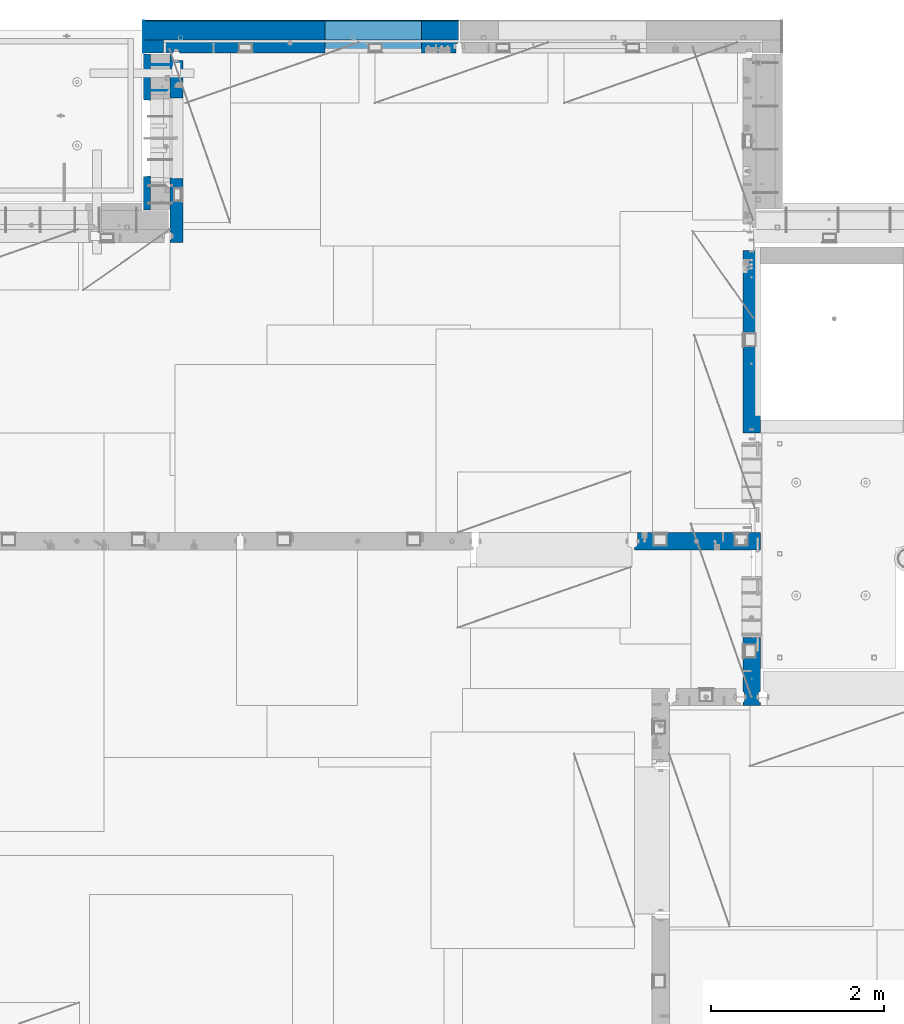
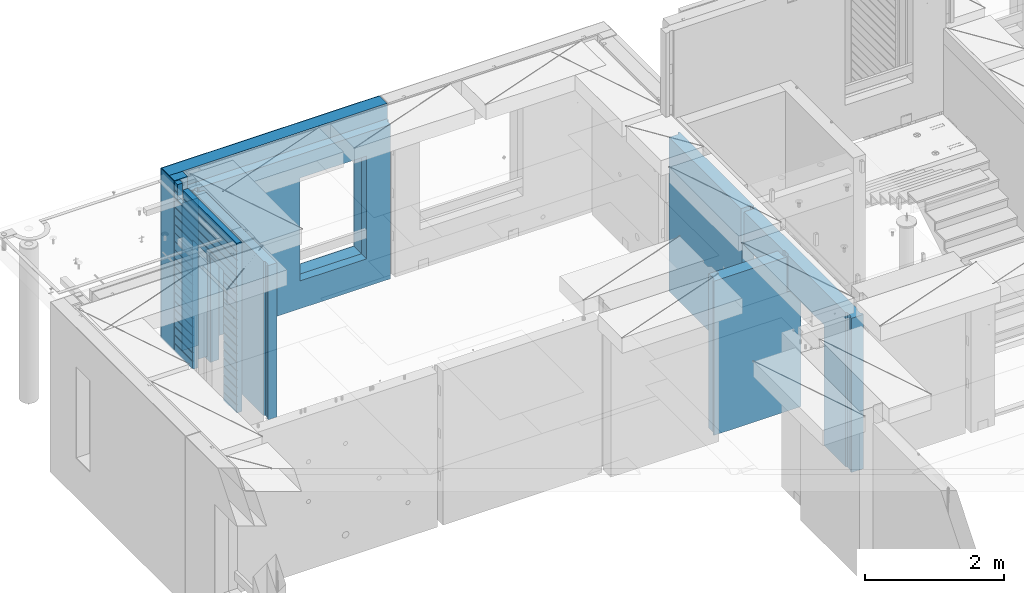
# One storey, part 228 of 341: 12 walls, 5 elements without a shape of their own.
"""IFC2X3 building model written with IfcOpenShell, lengths in millimetres."""

from ifc_helpers import new_model, si_unit, frame, origin_with_axes, place, context, subcontext, project, spatial, faceted_brep, material, type_object, element, aggregate, save


model = new_model("IFC2X3")

# Units and contexts
model_context = context("Model", 3, precision=1e-05, world=origin_with_axes())
body_context = subcontext(model_context, "Body", "Model", "MODEL_VIEW")
ifc_project = project(units=[si_unit("LENGTHUNIT", "METRE", prefix="MILLI"), si_unit("AREAUNIT", "SQUARE_METRE"), si_unit("VOLUMEUNIT", "CUBIC_METRE"), si_unit("MASSUNIT", "GRAM", prefix="KILO"), si_unit("TIMEUNIT", "SECOND"), si_unit("PLANEANGLEUNIT", "RADIAN"), si_unit("SOLIDANGLEUNIT", "STERADIAN"), si_unit("THERMODYNAMICTEMPERATUREUNIT", "DEGREE_CELSIUS"), si_unit("LUMINOUSINTENSITYUNIT", "LUMEN")], contexts=[model_context])

# Site, building, storey
site_placement = place(None, origin_with_axes())
site = spatial("IfcSite", under=ifc_project, at=site_placement, CompositionType="ELEMENT")
building_placement = place(site_placement, origin_with_axes())
building = spatial("IfcBuilding", under=site, at=building_placement, CompositionType="ELEMENT")
storey_placement = place(building_placement, origin_with_axes())
storey = spatial("IfcBuildingStorey", under=building, at=storey_placement, Name="5", CompositionType="ELEMENT", Elevation=0.0)

# Assembly, walls
assembly_1_placement = place(storey_placement, origin_with_axes())
assembly_1 = element("IfcElementAssembly", 1, at=assembly_1_placement, inside=storey, AssemblyPlace="NOTDEFINED", PredefinedType="REINFORCEMENT_UNIT")
ifc_material_1 = material(Name="Undefined")
wall_type_1 = type_object("IfcWallType", PredefinedType="NOTDEFINED")
wall_1_placement = place(assembly_1_placement, frame((11020.0, 22485.0002441406, 95115.0), z_axis=(0.0, 0.0, 1.0), x_axis=(-1.0, 3.00000001838171e-08, 0.0)))
wall_1 = element("IfcWall", 2, at=wall_1_placement, type_object=wall_type_1, material=ifc_material_1, Name="(PD)", context=body_context, shape_type="Brep", body=[
    faceted_brep([(0.0, 5.0, -1300.0), (0.0, 5.0, 1300.0), (280.0, 5.0, 1300.0), (280.0, 5.0, -1300.0), (0.0, -5.0, 1300.0), (280.0, -5.0, 1300.0), (0.0, -5.0, -1300.0), (280.0, -5.0, -1300.0)], [[[0, 1, 2, 3]], [[1, 4, 5, 2]], [[4, 6, 7, 5]], [[6, 0, 3, 7]], [[5, 7, 3, 2]], [[6, 4, 1, 0]]]),
])
wall_2_placement = place(assembly_1_placement, frame((11020.0, 22185.0002441406, 95115.0), z_axis=(0.0, 0.0, 1.0), x_axis=(-1.0, 3.00000001838171e-08, 0.0)))
wall_2 = element("IfcWall", 3, at=wall_2_placement, type_object=wall_type_1, material=ifc_material_1, Name="(PD)", context=body_context, shape_type="Brep", body=[
    faceted_brep([(0.0, 5.0, -1300.0), (0.0, 5.0, 1300.0), (280.0, 5.0, 1300.0), (280.0, 5.0, -1300.0), (0.0, -5.0, 1300.0), (280.0, -5.0, 1300.0), (0.0, -5.0, -1300.0), (280.0, -5.0, -1300.0)], [[[0, 1, 2, 3]], [[1, 4, 5, 2]], [[4, 6, 7, 5]], [[6, 0, 3, 7]], [[5, 7, 3, 2]], [[6, 4, 1, 0]]]),
])

# Assembly, wall
assembly_2_placement = place(storey_placement, origin_with_axes())
assembly_2 = element("IfcElementAssembly", 4, at=assembly_2_placement, inside=storey, AssemblyPlace="NOTDEFINED", PredefinedType="REINFORCEMENT_UNIT")
ifc_material_2 = material(Name="CONCRETE/C25/30")
wall_type_2 = type_object("IfcWallType", PredefinedType="NOTDEFINED")
wall_3_placement = place(assembly_2_placement, frame((17710.0, 18214.9992663657, 95112.5), z_axis=(0.0, 0.0, 1.0), x_axis=(0.0, 1.0, 0.0)))
wall_3 = element("IfcWall", 5, at=wall_3_placement, type_object=wall_type_2, material=ifc_material_2, context=body_context, shape_type="Brep", body=[
    faceted_brep([(2120.00073363433, -57.0000000000036, 1357.5), (2120.00073363433, -57.0000000000036, -1357.5), (2120.00073363433, 100.0, -1357.5), (2120.00073363433, 100.0, 1357.5), (2165.00073363433, -70.0000000000036, 1357.5), (2165.00073363433, -70.0000000000036, -1357.5), (45.0, 100.0, 1357.5), (45.0, 100.0, 762.5), (45.0, -57.0, 762.5), (45.0, -57.0, 1357.5), (15.0, -70.0, 762.5), (15.0, 100.0, 762.5), (15.0, -70.0, 1357.5), (15.0, 100.0, -1357.5), (15.0, -100.0, -1357.5), (15.0, -100.0, 1357.5), (2165.00073363433, -100.0, -1357.5), (2165.00073363433, -100.0, 1357.5)], [[[0, 1, 2, 3]], [[4, 5, 1, 0]], [[6, 7, 8, 9]], [[10, 8, 7, 11]], [[12, 9, 8, 10]], [[11, 13, 14, 15, 12, 10]], [[15, 14, 16, 17]], [[3, 6, 9, 12, 15, 17, 4, 0]], [[13, 11, 7, 6, 3, 2]], [[16, 14, 13, 2, 1, 5]], [[17, 16, 5, 4]]]),
])
aggregate(assembly_2, [wall_3])

assembly_3_placement = place(storey_placement, origin_with_axes())
assembly_3 = element("IfcElementAssembly", 6, at=assembly_3_placement, inside=storey, AssemblyPlace="NOTDEFINED", PredefinedType="REINFORCEMENT_UNIT")
wall_4_placement = place(assembly_3_placement, frame((17710.0, 15080.0, 95112.5), z_axis=(0.0, 0.0, 1.0), x_axis=(0.0, 1.0, 0.0)))
wall_4 = element("IfcWall", 7, at=wall_4_placement, type_object=wall_type_2, material=ifc_material_2, context=body_context, shape_type="Brep", body=[
    faceted_brep([(3089.99926636568, -57.0, 1357.5), (3089.99926636568, -57.0, 762.5), (3089.99926620436, 100.0, 762.5), (3089.99926636568, 100.0, 1357.5), (3119.99926636568, -70.0, 1357.5), (3119.99926636568, -69.9999995451544, 762.5), (1965.00000368528, 100.0, 1357.5), (1965.00000368528, 99.9999997455598, 762.5), (1951.9999991369, 80.0000000823711, 762.5), (1951.9999991369, 80.0000000823711, 1357.5), (1848.00000041054, 79.9999993903439, 762.5), (1848.00000041054, 79.9999993903439, 1357.5), (1835.0, 100.0, 762.5), (1835.0, 100.0, 1357.5), (790.003238525391, -100.0, -1357.5), (790.003238525391, 100.0, -1357.5), (790.003238525391, 100.0, 762.5), (790.003238525391, -100.0, 762.5), (164.999999999998, 100.0, -1357.5), (164.999999999996, 100.0, 1357.5), (47.9997742438973, -79.9991481948964, 1357.5), (47.9997742438991, -79.9991481948928, -1357.5), (152.000000457021, -79.9991466091124, -1357.5), (152.000000457019, -79.9991466091124, 1357.5), (34.9997701872417, -100.0, 1357.5), (34.9997701872435, -100.0, -1357.5), (0.0, -100.0, 1357.5), (0.0, -100.0, -1357.5), (0.0, 100.0, 1357.5), (0.0, 100.0, -1357.5), (35.0, 100.0, 1357.5), (35.0, 100.0, -1357.5), (48.0, 80.0, 1357.5), (48.0, 80.0, -1357.5), (152.0, 80.0, 1357.5), (152.0, 80.0, -1357.5), (165.0, -100.0, -1357.5), (164.999999999998, -99.9991455078125, 1357.5), (3119.99926636568, -100.0, 762.5), (3119.99926636568, -100.0, 1357.5)], [[[0, 1, 2, 3]], [[4, 5, 1, 0]], [[6, 7, 8, 9]], [[9, 8, 10, 11]], [[11, 10, 12, 13]], [[14, 15, 16, 17]], [[13, 12, 16, 15, 18, 19]], [[20, 21, 22, 23]], [[24, 25, 21, 20]], [[26, 27, 25, 24]], [[27, 26, 28, 29]], [[29, 28, 30, 31]], [[32, 33, 31, 30]], [[34, 35, 33, 32]], [[19, 18, 35, 34]], [[15, 14, 36, 22, 21, 25, 27, 29, 31, 33, 35, 18]], [[37, 23, 22, 36]], [[14, 17, 38, 39, 37, 36]], [[13, 19, 34, 32, 30, 28, 26, 24, 20, 23, 37, 39, 4, 0, 3, 6, 9, 11]], [[7, 6, 3, 2]], [[38, 17, 16, 12, 10, 8, 7, 2, 1, 5]], [[39, 38, 5, 4]]]),
])
aggregate(assembly_3, [wall_4])

assembly_4_placement = place(storey_placement, origin_with_axes())
assembly_4 = element("IfcElementAssembly", 8, at=assembly_4_placement, inside=storey, AssemblyPlace="NOTDEFINED", PredefinedType="REINFORCEMENT_UNIT")
wall_5_placement = place(assembly_4_placement, frame((16359.9991042544, 16980.0, 95112.5), z_axis=(0.0, 0.0, 1.0), x_axis=(1.0, 0.0, 0.0)))
wall_5 = element("IfcWall", 9, at=wall_5_placement, type_object=wall_type_2, material=ifc_material_2, context=body_context, shape_type="Brep", body=[
    faceted_brep([(1185.00089736511, 100.0, 1357.5), (1185.00089574558, -57.0, 1357.5), (1185.00089574558, -57.0, 742.5), (1185.00089736511, 99.9999999278843, 742.5), (1220.00089574558, -70.2708332915754, 1357.5), (1220.00089574558, -70.270833291579, 742.5), (1220.00089574558, 100.000001967095, 742.5), (0.0, -100.0, -1357.5), (0.0, -100.0, 1357.5), (0.0, -70.0000178764712, 1357.5), (0.0, -70.0000178764712, -1357.5), (30.0000412533973, -57.0, 1357.5), (30.0000412533973, -57.0, -1357.5), (30.0000000000009, 100.0, 1357.5), (30.0, 100.0, -1357.5), (1450.0, 100.0, -1357.5), (1450.0, -100.0, -1357.5), (1450.00089574558, 100.0, 742.5), (1450.0, -100.0, 742.5), (1220.00089574558, -100.0, 1357.5), (1220.00089574558, -100.0, 742.5), (1225.00089532057, 100.0, 742.5)], [[[0, 1, 2, 3]], [[4, 5, 2, 1]], [[6, 3, 2, 5]], [[7, 8, 9, 10]], [[11, 12, 10, 9]], [[13, 14, 12, 11]], [[15, 16, 7, 10, 12, 14]], [[16, 15, 17, 18]], [[19, 8, 7, 16, 18, 20]], [[17, 21, 6, 5, 20, 18]], [[19, 20, 5, 4]], [[0, 13, 11, 9, 8, 19, 4, 1]], [[21, 17, 15, 14, 13, 0, 3, 6]]]),
])
aggregate(assembly_4, [wall_5])

# Assembly, walls
assembly_5_placement = place(storey_placement, origin_with_axes())
assembly_5 = element("IfcElementAssembly", 10, at=assembly_5_placement, inside=storey, AssemblyPlace="NOTDEFINED", PredefinedType="REINFORCEMENT_UNIT")
ifc_material_3 = material()
wall_type_3 = type_object("IfcWallType", PredefinedType="NOTDEFINED")
wall_6_placement = place(assembly_5_placement, frame((10805.0, 22620.0, 95247.5), z_axis=(0.0, 0.0, 1.0), x_axis=(0.0, 1.0, 0.0)))
wall_6 = element("IfcWall", 11, at=wall_6_placement, type_object=wall_type_3, material=ifc_material_3, context=body_context, shape_type="Brep", body=[
    faceted_brep([(0.0, 110.0, -1492.5), (0.0, 110.0, 1492.5), (150.0, 110.0, 1492.5), (150.0, 110.0, -1492.5), (0.0, -110.0, 1492.5), (150.0, -110.0, 1492.5), (0.0, -110.0, -1492.5), (150.0, -110.0, -1492.5)], [[[0, 1, 2, 3]], [[1, 4, 5, 2]], [[4, 6, 7, 5]], [[6, 0, 3, 7]], [[5, 7, 3, 2]], [[6, 4, 1, 0]]]),
])
wall_7_placement = place(assembly_5_placement, frame((10915.0, 22880.0, 95247.5), z_axis=(0.0, 0.0, 1.0), x_axis=(1.0, 0.0, 0.0)))
wall_7 = element("IfcWall", 12, at=wall_7_placement, type_object=wall_type_3, material=ifc_material_3, context=body_context, shape_type="Brep", body=[
    faceted_brep([(-220.0, -110.0, -1492.5), (-220.0, 110.0, -1492.5), (3410.0, 110.0, -1492.5), (3410.0, -110.0, -1492.5), (-220.0, -110.0, 1492.5), (-220.0, 110.0, 1492.5), (3410.0, -110.0, 1492.5), (3410.0, 110.0, 1492.5), (1869.99971073172, 110.0, -1002.5), (2979.99971073172, 110.0, -1002.5), (2979.99971073172, 110.0, 807.5), (1869.99971073172, 110.0, 807.5), (1869.99971073172, -110.0, -1002.5), (1869.99971073172, -110.0, 807.5), (2979.99971073172, -110.0, 807.5), (2979.99971073172, -110.0, -1002.5)], [[[0, 1, 2, 3]], [[0, 4, 5, 1]], [[5, 4, 6, 7]], [[1, 5, 7, 2], [8, 9, 10, 11]], [[6, 3, 2, 7]], [[4, 0, 3, 6], [12, 13, 14, 15]], [[10, 14, 13, 11]], [[9, 15, 14, 10]], [[8, 12, 15, 9]], [[11, 13, 12, 8]]]),
])

# Wall
ifc_material_4 = material(Name="CONCRETE/C30/37")
wall_type_4 = type_object("IfcWallType", PredefinedType="NOTDEFINED")
wall_8_placement = place(assembly_1_placement, frame((10727.5, 20805.0, 95247.5), z_axis=(0.0, 0.0, 1.0), x_axis=(0.0, 1.0, 0.0)))
wall_8 = element("IfcWall", 13, at=wall_8_placement, type_object=wall_type_4, material=ifc_material_4, context=body_context, shape_type="Brep", body=[
    faceted_brep([(1800.0, -42.5, 1492.5), (1800.0, 42.5, 1492.5), (1705.0, 42.5, 1492.5), (1705.0, -42.5, 1492.5), (0.0, 42.5, -1492.5), (0.0, 42.5, -1357.00000005524), (384.998212827581, 42.5, -1357.00000005524), (384.998212827581, 42.5, -1492.5), (0.0, 32.4999992507037, -1355.00000000074), (386.174879582417, 32.4999992506928, -1355.0000000008), (0.0, 32.4999991127006, -1344.99999959956), (386.174879598653, 32.4999991126915, -1344.99999959957), (0.0, 42.5, -1343.00000011075), (384.998212827581, 42.5, -1343.00000011075), (0.0, 42.5, -1207.00000005524), (384.998212827581, 42.5, -1207.00000005524), (0.0, 32.4999992507037, -1205.00000000074), (386.174879582417, 32.4999992506928, -1205.0000000008), (0.0, 32.4999991127006, -1194.99999959956), (386.174879598653, 32.4999991126915, -1194.99999959957), (0.0, 42.5, -1193.00000011075), (384.998212827581, 42.5, -1193.00000011075), (0.0, 42.5, -1057.00000005524), (384.998212827581, 42.5, -1057.00000005524), (0.0, 32.4999992507037, -1055.00000000074), (386.174879582417, 32.4999992506928, -1055.0000000008), (0.0, 32.4999991127006, -1044.99999959956), (386.174879598653, 32.4999991126915, -1044.99999959957), (0.0, 42.5, -1043.00000011075), (384.998212827581, 42.5, -1043.00000011075), (0.0, 42.5, -907.000000055239), (384.998212827581, 42.5, -907.000000055239), (0.0, 32.4999992507037, -905.000000000742), (386.174879582417, 32.4999992506928, -905.0000000008), (0.0, 32.4999991127006, -894.99999959956), (386.174879598653, 32.4999991126915, -894.999999599575), (0.0, 42.5, -893.000000110755), (384.998212827581, 42.5, -893.000000110755), (0.0, 42.5, -757.000000055239), (384.998212827581, 42.5, -757.000000055239), (0.0, 32.4999992507037, -755.000000000742), (386.174879582417, 32.4999992506928, -755.0000000008), (0.0, 32.4999991127006, -744.99999959956), (386.174879598653, 32.4999991126915, -744.999999599575), (0.0, 42.5, -743.000000110755), (384.998212827581, 42.5, -743.000000110755), (0.0, 42.5, -607.000000055239), (384.998212827581, 42.5, -607.000000055239), (3.63797880709171e-12, 32.4999992507037, -605.000000000742), (386.174879582417, 32.4999992506928, -605.0000000008), (3.63797880709171e-12, 32.4999991127006, -594.99999959956), (386.174879598653, 32.4999991126915, -594.999999599575), (0.0, 42.5, -593.000000110755), (384.998212827581, 42.5, -593.000000110755), (0.0, 42.5, -457.000000055239), (384.998212827581, 42.5, -457.000000055239), (0.0, 32.4999992507037, -455.000000000742), (386.174879582417, 32.4999992506928, -455.0000000008), (0.0, 32.4999991127006, -444.99999959956), (386.174879598653, 32.4999991126915, -444.999999599575), (0.0, 42.5, -443.000000110755), (384.998212827581, 42.5, -443.000000110755), (0.0, 42.5, -307.000000055239), (384.998212827581, 42.5, -307.000000055239), (0.0, 32.4999992507037, -305.000000000742), (386.174879582417, 32.4999992506928, -305.0000000008), (0.0, 32.4999991127006, -294.99999959956), (386.174879598653, 32.4999991126915, -294.999999599575), (0.0, 42.5, -293.000000110755), (384.998212827581, 42.5, -293.000000110755), (0.0, 42.5, -157.000000055239), (384.998212827581, 42.5, -157.000000055239), (3.63797880709171e-12, 32.4999992507037, -155.000000000742), (386.174879582417, 32.4999992506928, -155.0000000008), (3.63797880709171e-12, 32.4999991127006, -144.99999959956), (386.174879598653, 32.4999991126915, -144.999999599575), (0.0, 42.5, -143.000000110755), (384.998212827581, 42.5, -143.000000110755), (0.0, 42.5, -7.00000005523907), (384.998212827581, 42.5, -7.00000005523907), (0.0, 32.4999992507037, -5.00000000074215), (386.174879582417, 32.4999992506928, -5.00000000080036), (0.0, 32.4999991127006, 5.0000004004396), (386.174879598653, 32.4999991126915, 5.00000040042505), (0.0, 42.5, 6.99999988924537), (384.998212827581, 42.5, 6.99999988924537), (0.0, 42.5, 142.999999944761), (384.998212827581, 42.5, 142.999999944761), (-3.63797880709171e-12, 32.4999992507037, 144.999999999258), (386.174879582417, 32.4999992506928, 144.9999999992), (-3.63797880709171e-12, 32.4999991127006, 155.00000040044), (386.174879598653, 32.4999991126915, 155.000000400425), (0.0, 42.5, 156.999999889245), (384.998212827581, 42.5, 156.999999889245), (0.0, 42.5, 292.999999944761), (384.998212827581, 42.5, 292.999999944761), (-3.63797880709171e-12, 32.4999992507037, 294.999999999258), (386.174879582417, 32.4999992506928, 294.9999999992), (-3.63797880709171e-12, 32.4999991127006, 305.00000040044), (386.174879598653, 32.4999991126915, 305.000000400425), (0.0, 42.5, 306.999999889245), (384.998212827581, 42.5, 306.999999889245), (0.0, 42.5, 442.999999944761), (384.998212827581, 42.5, 442.999999944761), (0.0, 32.4999992507037, 444.999999999258), (386.174879582417, 32.4999992506928, 444.9999999992), (0.0, 32.4999991127006, 455.00000040044), (386.174879598653, 32.4999991126915, 455.000000400425), (0.0, 42.5, 456.999999889245), (384.998212827581, 42.5, 456.999999889245), (0.0, 42.5, 592.999999944761), (384.998212827581, 42.5, 592.999999944761), (3.63797880709171e-12, 32.4999992507037, 594.999999999258), (386.174879582417, 32.4999992506928, 594.9999999992), (3.63797880709171e-12, 32.4999991127006, 605.00000040044), (386.174879598653, 32.4999991126915, 605.000000400425), (0.0, 42.5, 606.999999889245), (384.998212827581, 42.5, 606.999999889245), (0.0, 42.5, 742.999999944761), (384.998212827581, 42.5, 742.999999944761), (0.0, 32.4999992507037, 744.999999999258), (386.174879582417, 32.4999992506928, 744.9999999992), (0.0, 32.4999991127006, 755.00000040044), (386.174879598653, 32.4999991126915, 755.000000400425), (0.0, 42.5, 756.999999889245), (384.998212827581, 42.5, 756.999999889245), (0.0, 42.5, 1206.99999988925), (1800.0, 42.5, 1206.99999988925), (1800.0, 32.4999991126897, 1205.00000040043), (0.0, 32.4999991127006, 1205.00000040044), (1800.0, 32.4999992507001, 1194.99999999923), (0.0, 32.4999992507037, 1194.99999999926), (0.0, 42.5, 1192.99999994476), (1800.0, 42.5, 1192.99999994476), (1800.0, 42.5, 1056.99999988925), (0.0, 42.5, 1056.99999988925), (1800.0, 32.4999991126897, 1055.00000040043), (0.0, 32.4999991127006, 1055.00000040044), (1800.0, 32.4999992507001, 1044.99999999923), (0.0, 32.4999992507037, 1044.99999999926), (0.0, 42.5, 1042.99999994476), (1800.0, 42.5, 1042.99999994476), (1800.0, 42.5, 906.999999889245), (0.0, 42.5, 906.999999889245), (1800.0, 32.4999991126897, 905.000000400425), (0.0, 32.4999991127006, 905.00000040044), (1800.0, 32.4999992507001, 894.999999999229), (0.0, 32.4999992507037, 894.999999999258), (0.0, 42.5, 892.999999944761), (1800.0, 42.5, 892.999999944761), (1800.0, 42.5, -1357.00000005524), (1800.0, 42.5, -1492.5), (1274.99821282758, 42.5, -1492.5), (1274.99821282758, 42.5, -1357.00000005524), (1800.0, 32.4999992507001, -1355.00000000077), (1273.82154607274, 32.4999992506928, -1355.0000000008), (1800.0, 32.4999991126897, -1344.99999959957), (1273.82154605651, 32.4999991126915, -1344.99999959957), (1800.0, 42.5, -1343.00000011075), (1274.99821282758, 42.5, -1343.00000011075), (1800.0, 42.5, -1207.00000005524), (1274.99821282758, 42.5, -1207.00000005524), (1800.0, 32.4999992507001, -1205.00000000077), (1273.82154607274, 32.4999992506928, -1205.0000000008), (1800.0, 32.4999991126897, -1194.99999959957), (1273.82154605651, 32.4999991126915, -1194.99999959957), (1800.0, 42.5, -1193.00000011075), (1274.99821282758, 42.5, -1193.00000011075), (1800.0, 42.5, -1057.00000005524), (1274.99821282758, 42.5, -1057.00000005524), (1800.0, 32.4999992507001, -1055.00000000077), (1273.82154607274, 32.4999992506928, -1055.0000000008), (1800.0, 32.4999991126897, -1044.99999959957), (1273.82154605651, 32.4999991126915, -1044.99999959957), (1800.0, 42.5, -1043.00000011075), (1274.99821282758, 42.5, -1043.00000011075), (1800.0, 42.5, -907.000000055239), (1274.99821282758, 42.5, -907.000000055239), (1800.0, 32.4999992507001, -905.000000000771), (1273.82154607274, 32.4999992506928, -905.0000000008), (1800.0, 32.4999991126897, -894.999999599575), (1273.82154605651, 32.4999991126915, -894.999999599575), (1800.0, 42.5, -893.000000110755), (1274.99821282758, 42.5, -893.000000110755), (1800.0, 42.5, -757.000000055239), (1274.99821282758, 42.5, -757.000000055239), (1800.0, 32.4999992507001, -755.000000000771), (1273.82154607274, 32.4999992506928, -755.0000000008), (1800.0, 32.4999991126897, -744.999999599575), (1273.82154605651, 32.4999991126915, -744.999999599575), (1800.0, 42.5, -743.000000110755), (1274.99821282758, 42.5, -743.000000110755), (1800.0, 42.5, -607.000000055239), (1274.99821282758, 42.5, -607.000000055239), (1800.0, 32.4999992507001, -605.000000000771), (1273.82154607274, 32.4999992506928, -605.0000000008), (1800.0, 32.4999991126897, -594.999999599575), (1273.82154605651, 32.4999991126915, -594.999999599575), (1800.0, 42.5, -593.000000110755), (1274.99821282758, 42.5, -593.000000110755), (1800.0, 42.5, -457.000000055239), (1274.99821282758, 42.5, -457.000000055239), (1800.0, 32.4999992507001, -455.000000000771), (1273.82154607274, 32.4999992506928, -455.0000000008), (1800.0, 32.4999991126897, -444.999999599575), (1273.82154605651, 32.4999991126915, -444.999999599575), (1800.0, 42.5, -443.000000110755), (1274.99821282758, 42.5, -443.000000110755), (1800.0, 42.5, -307.000000055239), (1274.99821282758, 42.5, -307.000000055239), (1800.0, 32.4999992507001, -305.000000000771), (1273.82154607274, 32.4999992506928, -305.0000000008), (1800.0, 32.4999991126897, -294.999999599575), (1273.82154605651, 32.4999991126915, -294.999999599575), (1800.0, 42.5, -293.000000110755), (1274.99821282758, 42.5, -293.000000110755), (1800.0, 42.5, -157.000000055239), (1274.99821282758, 42.5, -157.000000055239), (1800.0, 32.4999992507001, -155.000000000771), (1273.82154607274, 32.4999992506928, -155.0000000008), (1800.0, 32.4999991126897, -144.999999599575), (1273.82154605651, 32.4999991126915, -144.999999599575), (1800.0, 42.5, -143.000000110755), (1274.99821282758, 42.5, -143.000000110755), (1800.0, 42.5, -7.00000005523907), (1274.99821282758, 42.5, -7.00000005523907), (1800.0, 32.4999992507001, -5.00000000077125), (1273.82154607274, 32.4999992506928, -5.00000000080036), (1800.0, 32.4999991126897, 5.00000040042505), (1273.82154605651, 32.4999991126915, 5.00000040042505), (1800.0, 42.5, 6.99999988924537), (1274.99821282758, 42.5, 6.99999988924537), (1800.0, 42.5, 142.999999944761), (1274.99821282758, 42.5, 142.999999944761), (1800.0, 32.4999992507001, 144.999999999229), (1273.82154607274, 32.4999992506928, 144.9999999992), (1800.0, 32.4999991126897, 155.000000400425), (1273.82154605651, 32.4999991126915, 155.000000400425), (1800.0, 42.5, 156.999999889245), (1274.99821282758, 42.5, 156.999999889245), (1800.0, 42.5, 292.999999944761), (1274.99821282758, 42.5, 292.999999944761), (1800.0, 32.4999992507001, 294.999999999229), (1273.82154607274, 32.4999992506928, 294.9999999992), (1800.0, 32.4999991126897, 305.000000400425), (1273.82154605651, 32.4999991126915, 305.000000400425), (1800.0, 42.5, 306.999999889245), (1274.99821282758, 42.5, 306.999999889245), (1800.0, 42.5, 442.999999944761), (1274.99821282758, 42.5, 442.999999944761), (1800.0, 32.4999992507001, 444.999999999229), (1273.82154607274, 32.4999992506928, 444.9999999992), (1800.0, 32.4999991126897, 455.000000400425), (1273.82154605651, 32.4999991126915, 455.000000400425), (1800.0, 42.5, 456.999999889245), (1274.99821282758, 42.5, 456.999999889245), (1800.0, 42.5, 592.999999944761), (1274.99821282758, 42.5, 592.999999944761), (1800.0, 32.4999992507001, 594.999999999229), (1273.82154607274, 32.4999992506928, 594.9999999992), (1800.0, 32.4999991126897, 605.000000400425), (1273.82154605651, 32.4999991126915, 605.000000400425), (1800.0, 42.5, 606.999999889245), (1274.99821282758, 42.5, 606.999999889245), (1800.0, 42.5, 742.999999944761), (1274.99821282758, 42.5, 742.999999944761), (1800.0, 32.4999992507001, 744.999999999229), (1273.82154607274, 32.4999992506928, 744.9999999992), (1800.0, 32.4999991126897, 755.000000400425), (1273.82154605651, 32.4999991126915, 755.000000400425), (1800.0, 42.5, 756.999999889245), (1274.99821282758, 42.5, 756.999999889245), (395.000271651108, 42.5, 782.5), (384.998212827581, 42.5, 782.5), (1274.99821282758, 42.5, 782.5), (1265.00027165111, 42.5, 782.5), (394.999879494248, -42.5, 787.502857142856), (1264.99654616091, -42.5, 787.502857142856), (394.999879494248, -42.5, 782.5), (394.999879494248, -42.5, -1492.5), (0.0, -42.5, -1492.5), (-3.63797880709171e-12, 32.4999992507037, 1344.99999999926), (0.0, 42.5, 1342.99999994476), (0.0, -42.5, 1492.5), (0.0, 42.5, 1492.5), (0.0, 42.5, 1356.99999988925), (-3.63797880709171e-12, 32.4999991127006, 1355.00000040044), (1555.0, 42.5, 1356.99999988925), (1555.0, 32.4999991126915, 1355.00000040043), (1555.0, 32.4999992506928, 1344.9999999992), (1555.0, 42.5, 1342.99999994476), (1800.0, 42.5, 1342.99999994476), (1555.0, 42.5, 1222.5), (1705.0, 42.5, 1222.5), (1705.0, 42.5, 1343.0), (1800.0, 32.4999992507001, 1344.99999999923), (1705.0, 32.5, 1345.0), (1800.0, 32.4999991126897, 1355.00000040043), (1705.0, 32.5, 1355.0), (1800.0, 42.5, 1356.99999988925), (1705.0, 42.5, 1357.0), (1800.0, -42.5, -1492.5), (1264.99654616091, -42.5, -1492.5), (1264.99654616091, -42.5, 782.5), (1705.0, -42.5, 1222.5), (1555.0, -42.5, 1222.5), (1555.0, -42.5, 1492.5), (1555.0, 42.5, 1492.5)], [[[0, 1, 2, 3]], [[4, 5, 6, 7]], [[5, 8, 9, 6]], [[8, 10, 11, 9]], [[10, 12, 13, 11]], [[12, 14, 15, 13]], [[14, 16, 17, 15]], [[16, 18, 19, 17]], [[18, 20, 21, 19]], [[20, 22, 23, 21]], [[22, 24, 25, 23]], [[24, 26, 27, 25]], [[26, 28, 29, 27]], [[28, 30, 31, 29]], [[30, 32, 33, 31]], [[32, 34, 35, 33]], [[34, 36, 37, 35]], [[36, 38, 39, 37]], [[38, 40, 41, 39]], [[40, 42, 43, 41]], [[42, 44, 45, 43]], [[44, 46, 47, 45]], [[46, 48, 49, 47]], [[48, 50, 51, 49]], [[50, 52, 53, 51]], [[52, 54, 55, 53]], [[54, 56, 57, 55]], [[56, 58, 59, 57]], [[58, 60, 61, 59]], [[60, 62, 63, 61]], [[62, 64, 65, 63]], [[64, 66, 67, 65]], [[66, 68, 69, 67]], [[68, 70, 71, 69]], [[70, 72, 73, 71]], [[72, 74, 75, 73]], [[74, 76, 77, 75]], [[76, 78, 79, 77]], [[78, 80, 81, 79]], [[80, 82, 83, 81]], [[82, 84, 85, 83]], [[84, 86, 87, 85]], [[86, 88, 89, 87]], [[88, 90, 91, 89]], [[90, 92, 93, 91]], [[92, 94, 95, 93]], [[94, 96, 97, 95]], [[96, 98, 99, 97]], [[98, 100, 101, 99]], [[100, 102, 103, 101]], [[102, 104, 105, 103]], [[104, 106, 107, 105]], [[106, 108, 109, 107]], [[108, 110, 111, 109]], [[110, 112, 113, 111]], [[112, 114, 115, 113]], [[114, 116, 117, 115]], [[116, 118, 119, 117]], [[118, 120, 121, 119]], [[120, 122, 123, 121]], [[122, 124, 125, 123]], [[126, 127, 128, 129]], [[129, 128, 130, 131]], [[132, 131, 130, 133]], [[134, 135, 132, 133]], [[135, 134, 136, 137]], [[137, 136, 138, 139]], [[140, 139, 138, 141]], [[142, 143, 140, 141]], [[143, 142, 144, 145]], [[145, 144, 146, 147]], [[148, 147, 146, 149]], [[150, 151, 152, 153]], [[154, 150, 153, 155]], [[156, 154, 155, 157]], [[158, 156, 157, 159]], [[160, 158, 159, 161]], [[162, 160, 161, 163]], [[164, 162, 163, 165]], [[166, 164, 165, 167]], [[168, 166, 167, 169]], [[170, 168, 169, 171]], [[172, 170, 171, 173]], [[174, 172, 173, 175]], [[176, 174, 175, 177]], [[178, 176, 177, 179]], [[180, 178, 179, 181]], [[182, 180, 181, 183]], [[184, 182, 183, 185]], [[186, 184, 185, 187]], [[188, 186, 187, 189]], [[190, 188, 189, 191]], [[192, 190, 191, 193]], [[194, 192, 193, 195]], [[196, 194, 195, 197]], [[198, 196, 197, 199]], [[200, 198, 199, 201]], [[202, 200, 201, 203]], [[204, 202, 203, 205]], [[206, 204, 205, 207]], [[208, 206, 207, 209]], [[210, 208, 209, 211]], [[212, 210, 211, 213]], [[214, 212, 213, 215]], [[216, 214, 215, 217]], [[218, 216, 217, 219]], [[220, 218, 219, 221]], [[222, 220, 221, 223]], [[224, 222, 223, 225]], [[226, 224, 225, 227]], [[228, 226, 227, 229]], [[230, 228, 229, 231]], [[232, 230, 231, 233]], [[234, 232, 233, 235]], [[236, 234, 235, 237]], [[238, 236, 237, 239]], [[240, 238, 239, 241]], [[242, 240, 241, 243]], [[244, 242, 243, 245]], [[246, 244, 245, 247]], [[248, 246, 247, 249]], [[250, 248, 249, 251]], [[252, 250, 251, 253]], [[254, 252, 253, 255]], [[256, 254, 255, 257]], [[258, 256, 257, 259]], [[260, 258, 259, 261]], [[262, 260, 261, 263]], [[264, 262, 263, 265]], [[266, 264, 265, 267]], [[268, 266, 267, 269]], [[270, 268, 269, 271]], [[272, 273, 125, 124, 148, 149, 270, 271, 274, 275]], [[276, 273, 272, 275, 274, 277]], [[278, 279, 7, 6, 9, 11, 13, 15, 17, 19, 21, 23, 25, 27, 29, 31, 33, 35, 37, 39, 41, 43, 45, 47, 49, 51, 53, 55, 57, 59, 61, 63, 65, 67, 69, 71, 73, 75, 77, 79, 81, 83, 85, 87, 89, 91, 93, 95, 97, 99, 101, 103, 105, 107, 109, 111, 113, 115, 117, 119, 121, 123, 125, 273, 276]], [[280, 4, 7, 279]], [[281, 282, 126, 129, 131, 132, 135, 137, 139, 140, 143, 145, 147, 148, 124, 122, 120, 118, 116, 114, 112, 110, 108, 106, 104, 102, 100, 98, 96, 94, 92, 90, 88, 86, 84, 82, 80, 78, 76, 74, 72, 70, 68, 66, 64, 62, 60, 58, 56, 54, 52, 50, 48, 46, 44, 42, 40, 38, 36, 34, 32, 30, 28, 26, 24, 22, 20, 18, 16, 14, 12, 10, 8, 5, 4, 280, 283, 284, 285, 286]], [[286, 285, 287, 288]], [[281, 286, 288, 289]], [[282, 281, 289, 290]], [[291, 127, 126, 282, 290, 292, 293, 294]], [[295, 291, 294, 296]], [[297, 295, 296, 298]], [[299, 297, 298, 300]], [[1, 0, 301, 151, 150, 154, 156, 158, 160, 162, 164, 166, 168, 170, 172, 174, 176, 178, 180, 182, 184, 186, 188, 190, 192, 194, 196, 198, 200, 202, 204, 206, 208, 210, 212, 214, 216, 218, 220, 222, 224, 226, 228, 230, 232, 234, 236, 238, 240, 242, 244, 246, 248, 250, 252, 254, 256, 258, 260, 262, 264, 266, 268, 270, 149, 146, 144, 142, 141, 138, 136, 134, 133, 130, 128, 127, 291, 295, 297, 299]], [[151, 301, 302, 152]], [[303, 277, 274, 271, 269, 267, 265, 263, 261, 259, 257, 255, 253, 251, 249, 247, 245, 243, 241, 239, 237, 235, 233, 231, 229, 227, 225, 223, 221, 219, 217, 215, 213, 211, 209, 207, 205, 203, 201, 199, 197, 195, 193, 191, 189, 187, 185, 183, 181, 179, 177, 175, 173, 171, 169, 167, 165, 163, 161, 159, 157, 155, 153, 152, 302]], [[302, 301, 0, 3, 304, 305, 306, 283, 280, 279, 278, 276, 277, 303]], [[284, 283, 306, 307]], [[285, 284, 307, 287]], [[306, 305, 292, 290, 289, 288, 287, 307]], [[304, 293, 292, 305]], [[3, 2, 300, 298, 296, 294, 293, 304]], [[1, 299, 300, 2]]]),
])

wall_type_5 = type_object("IfcWallType", PredefinedType="NOTDEFINED")
wall_9_placement = place(assembly_5_placement, frame((11142.5, 22695.0, 95112.5), z_axis=(0.0, 0.0, 1.0), x_axis=(1.0, 0.0, 0.0)))
wall_9 = element("IfcWall", 14, at=wall_9_placement, type_object=wall_type_5, material=ifc_material_2, context=body_context, shape_type="Brep", body=[
    faceted_brep([(1642.49971073172, 75.0, 942.5), (1642.49971073172, -75.0000009442883, 942.5), (1642.49971073172, -75.0000001775006, -867.5), (1642.49971073172, 75.0, -867.5), (2752.49971073172, -74.999999784668, -867.5), (2752.49971073172, 75.0, -867.5), (2752.49971073172, -75.0000005514557, 942.5), (2752.49971073172, 75.0, 942.5), (-227.5, 75.0, -1357.5), (-227.5, 75.0, 1357.5), (3182.5, 75.0, 1357.5), (3182.5, 75.0, -1357.5), (-227.5, -75.0, -1357.5), (-227.5, -75.0, 1357.5), (-117.5, -75.0, -1357.5), (-117.5, -75.0, 1357.5), (-104.499999589396, -54.9999993903875, -1357.5), (-104.499999589396, -54.9999993903875, 1357.5), (-50.4999996848892, -54.9999994175341, -1357.5), (-50.4999996848892, -54.9999994175341, 1357.5), (-37.4999972154728, -75.0000022791319, 1357.5), (-37.4999972154728, -75.0, -1357.5), (3152.5, -75.0000000212349, 1357.5), (3152.5, 24.9999980926514, 1357.5), (3182.5, 45.0, 1357.5), (3182.5, 45.0, -1357.5), (3152.5, -75.0, -1357.5), (3152.5, 24.9999980926514, -1357.5)], [[[0, 1, 2, 3]], [[3, 2, 4, 5]], [[5, 4, 6, 7]], [[7, 6, 1, 0]], [[8, 9, 10, 11], [3, 5, 7, 0]], [[12, 13, 9, 8]], [[13, 12, 14, 15]], [[15, 14, 16, 17]], [[17, 16, 18, 19]], [[20, 19, 18, 21]], [[10, 9, 13, 15, 17, 19, 20, 22, 23, 24]], [[11, 10, 24, 25]], [[26, 21, 18, 16, 14, 12, 8, 11, 25, 27]], [[24, 23, 27, 25]], [[22, 26, 27, 23]], [[20, 21, 26, 22], [2, 1, 6, 4]]]),
])

wall_10_placement = place(assembly_1_placement, frame((11065.0, 20430.0, 95112.5), z_axis=(0.0, 0.0, 1.0), x_axis=(0.0, 1.0, 0.0)))
wall_10 = element("IfcWall", 15, at=wall_10_placement, type_object=wall_type_5, material=ifc_material_2, context=body_context, shape_type="Brep", body=[
    faceted_brep([(124.995187227563, 75.0, 1357.5), (124.995187227563, 75.0, -1357.5), (114.995187227563, 55.0, -1357.5), (114.995187227563, 55.0, 1357.5), (-0.00481277243670775, -75.0, -1357.5), (-0.00481277243670775, -75.0, 1357.5), (-0.00481277243670775, 75.0, 1357.5), (-0.00481277243670775, 75.0, -1357.5), (24.9951872275633, 75.0, 1357.5), (24.9951872275633, 75.0, -1357.5), (34.9951872275633, 55.0, 1357.5), (34.9951872275633, 55.0, -1357.5), (47.9951869124525, 54.9999994175378, 1357.5), (47.9951869124525, 54.9999994175378, -1357.5), (101.995186816988, 54.9999993903693, 1357.5), (101.995186816988, 54.9999993903693, -1357.5), (2105.0, -75.0, 1357.5), (2105.0, 32.0, 1357.5), (2175.0, 45.0, 1357.5), (2175.0, 75.0, 1357.5), (2105.0, -75.0, -1357.5), (2105.0, 32.0, -1357.5), (2175.0, 45.0, -1357.5), (2175.0, 75.0, -1357.5), (743.846425497264, 75.0, -1357.5), (1666.15411780495, 75.0, -1357.5), (1666.15411780496, 75.0, 948.653846153844), (743.846425497261, 75.0, 948.653846153844), (740.000271651108, -75.0, -1357.5), (740.000271651108, -75.0, 952.5), (1670.00027165111, -75.0, 952.5), (1670.00027165111, -75.0, -1357.5)], [[[0, 1, 2, 3]], [[4, 5, 6, 7]], [[7, 6, 8, 9]], [[10, 11, 9, 8]], [[12, 13, 11, 10]], [[14, 15, 13, 12]], [[3, 2, 15, 14]], [[12, 10, 8, 6, 5, 16, 17, 18, 19, 0, 3, 14]], [[16, 20, 21, 17]], [[17, 21, 22, 18]], [[23, 19, 18, 22]], [[24, 1, 0, 19, 23, 25, 26, 27]], [[4, 7, 9, 11, 13, 15, 2, 1, 24, 28]], [[20, 16, 5, 4, 28, 29, 30, 31]], [[23, 22, 21, 20, 31, 25]], [[30, 26, 25, 31]], [[29, 27, 26, 30]], [[28, 24, 27, 29]]]),
])

aggregate(assembly_1, [wall_1, wall_2, wall_8, wall_10])

wall_type_6 = type_object("IfcWallType", PredefinedType="NOTDEFINED")
wall_11_placement = place(assembly_5_placement, frame((10690.0, 22620.0, 95247.5), z_axis=(0.0, 0.0, 1.0), x_axis=(0.0, 1.0, 0.0)))
wall_11 = element("IfcWall", 16, at=wall_11_placement, type_object=wall_type_6, material=ifc_material_4, context=body_context, shape_type="Brep", body=[
    faceted_brep([(0.0, 5.0, -1492.5), (0.0, 5.0, 1492.5), (370.0, 5.0, 1492.5), (370.0, 5.0, -1492.5), (0.0, -5.0, 1492.5), (370.0, -5.0, 1492.5), (0.0, -5.0, -1492.5), (370.0, -5.0, -1492.5)], [[[0, 1, 2, 3]], [[1, 4, 5, 2]], [[4, 6, 7, 5]], [[6, 0, 3, 7]], [[5, 7, 3, 2]], [[6, 4, 1, 0]]]),
])

wall_12_placement = place(assembly_5_placement, frame((10915.0, 22995.0, 95247.5), z_axis=(0.0, 0.0, 1.0), x_axis=(1.0, 0.0, 0.0)))
wall_12 = element("IfcWall", 17, at=wall_12_placement, type_object=wall_type_6, material=ifc_material_4, context=body_context, shape_type="Brep", body=[
    faceted_brep([(-230.0, -5.0, -1492.5), (-230.0, 5.0, -1492.5), (3410.0, 5.0, -1492.5), (3410.0, -5.0, -1492.5), (-230.0, -5.0, 1492.5), (-230.0, 5.0, 1492.5), (3410.0, -5.0, 1492.5), (3410.0, 5.0, 1492.5), (1869.99971073172, 5.0, -1002.5), (2979.99971073172, 5.0, -1002.5), (2979.99971073172, 5.0, 807.5), (1869.99971073172, 5.0, 807.5), (1869.99971073172, -5.0, -1002.5), (1869.99971073172, -5.0, 807.5), (2979.99971073172, -5.0, 807.5), (2979.99971073172, -5.0, -1002.5)], [[[0, 1, 2, 3]], [[0, 4, 5, 1]], [[5, 4, 6, 7]], [[1, 5, 7, 2], [8, 9, 10, 11]], [[6, 3, 2, 7]], [[4, 0, 3, 6], [12, 13, 14, 15]], [[10, 14, 13, 11]], [[9, 15, 14, 10]], [[8, 12, 15, 9]], [[11, 13, 12, 8]]]),
])

aggregate(assembly_5, [wall_11, wall_6, wall_7, wall_12, wall_9])

save(model, "model.ifc")
